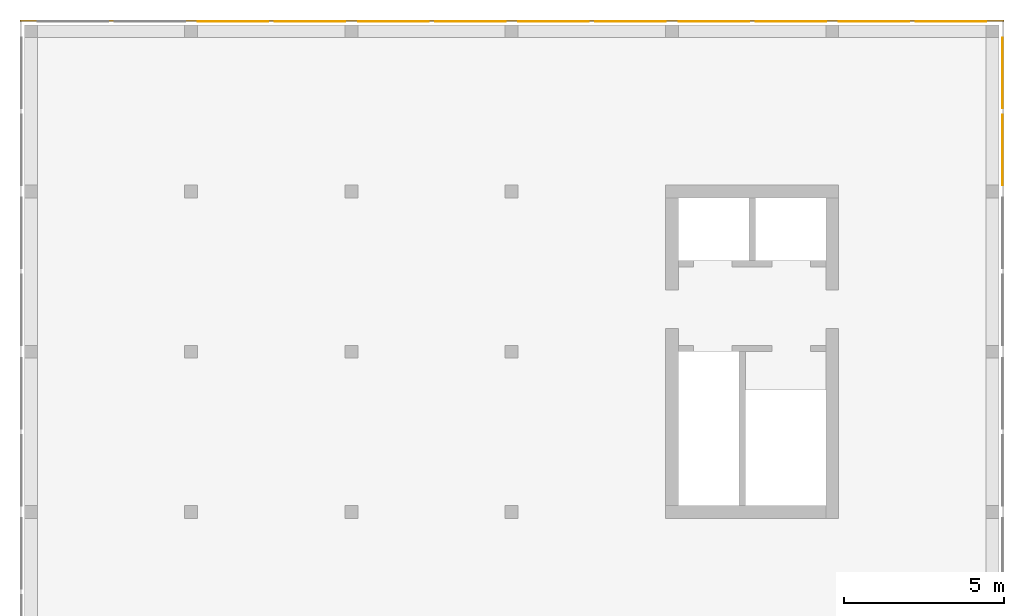
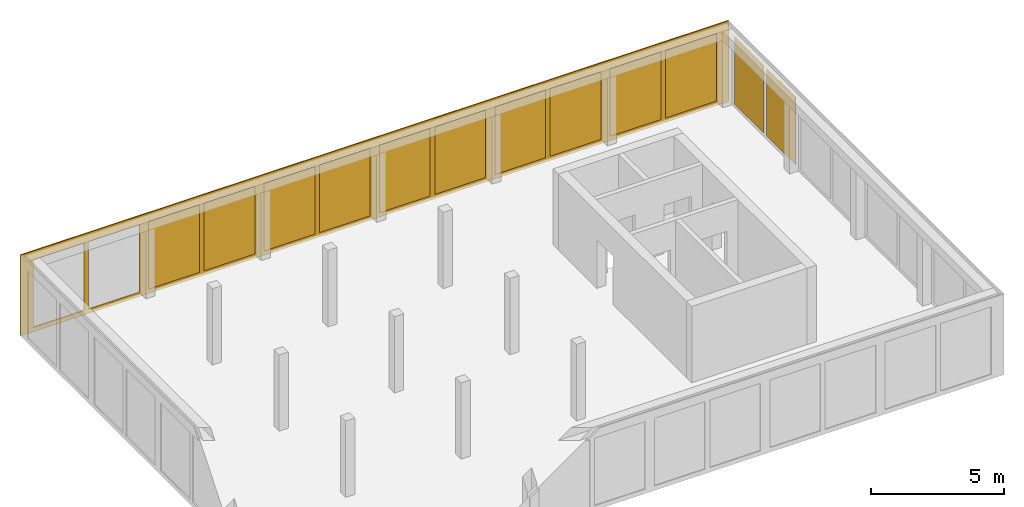
# One storey, part 3 of 3: 13 curtain walls.
"""IFC2X3 building model written with IfcOpenShell, lengths in metres."""

from ifc_helpers import new_model, entity, si_unit, converted_unit, frame, origin, place, context, subcontext, project, spatial, faceted_brep, material, element, save


model = new_model("IFC2X3")

# Units and contexts
model_context = context("Model", 3, precision=1e-05, world=origin())
body_context = subcontext(model_context, "Body", "Model", "MODEL_VIEW")
ifc_project = project(units=[si_unit("LENGTHUNIT", "METRE"), si_unit("AREAUNIT", "SQUARE_METRE"), si_unit("VOLUMEUNIT", "CUBIC_METRE"), si_unit("MASSUNIT", "GRAM", prefix="KILO"), converted_unit("PLANEANGLEUNIT", "DEGREE", entity("IfcPlaneAngleMeasure", 0.0174532925199433), si_unit("PLANEANGLEUNIT", "RADIAN"), dimensions=[0, 0, 0, 0, 0, 0, 0])], contexts=[model_context])

# Site, building, storey
site_placement = place(None, origin())
site = spatial("IfcSite", under=ifc_project, at=site_placement, CompositionType="ELEMENT")
building_placement = place(site_placement, origin())
building = spatial("IfcBuilding", under=site, at=building_placement, CompositionType="ELEMENT")
storey_placement = place(building_placement, frame((0.0, 0.0, 16.0)))
storey = spatial("IfcBuildingStorey", under=building, at=storey_placement, Name="4. Obergeschoss", CompositionType="ELEMENT", Elevation=16.0)

# Curtain walls
ifc_material_1 = material(Name="ALU")
curtain_wall_1_placement = place(storey_placement, frame((-0.139330706017223, 20.5, -0.2)))
element("IfcCurtainWall", 1, at=curtain_wall_1_placement, inside=storey, material=ifc_material_1, Name="Profil SN standard", context=body_context, shape_type="Brep", body=[
    faceted_brep([(0.0, 0.05, 3.7), (30.7, 0.05, 3.7), (30.7, 0.0, 3.7), (0.0, 0.0, 3.7), (30.7, 0.05, 0.0), (0.0, 0.05, 0.0), (0.0, 0.0, 0.0), (30.7, 0.0, 0.0), (27.95, 0.0, 0.2), (27.95, 0.0, 3.3), (27.95, 0.05, 3.3), (27.95, 0.05, 0.2), (27.75, 0.05, 0.2), (27.75, 0.05, 3.3), (27.75, 0.0, 3.3), (27.75, 0.0, 0.2), (22.95, 0.0, 0.2), (22.95, 0.0, 3.3), (22.95, 0.05, 3.3), (22.95, 0.05, 0.2), (22.75, 0.05, 0.2), (22.75, 0.05, 3.3), (22.75, 0.0, 3.3), (22.75, 0.0, 0.2), (17.75, 0.05, 0.2), (17.75, 0.05, 3.3), (17.75, 0.0, 3.3), (17.75, 0.0, 0.2), (17.95, 0.0, 0.2), (17.95, 0.0, 3.3), (17.95, 0.05, 3.3), (17.95, 0.05, 0.2), (25.15, 0.0, 0.2), (25.15, 0.05, 0.2), (25.15, 0.05, 3.3), (25.15, 0.0, 3.3), (25.55, 0.05, 0.2), (25.55, 0.0, 0.2), (25.55, 0.0, 3.3), (25.55, 0.05, 3.3), (20.15, 0.0, 0.2), (20.15, 0.05, 0.2), (20.15, 0.05, 3.3), (20.15, 0.0, 3.3), (20.55, 0.05, 0.2), (20.55, 0.0, 0.2), (20.55, 0.0, 3.3), (20.55, 0.05, 3.3), (30.15, 0.0, 0.2), (30.15, 0.05, 0.2), (30.15, 0.05, 3.3), (30.15, 0.0, 3.3), (2.75, 0.05, 0.2), (2.75, 0.05, 3.3), (2.75, 0.0, 3.3), (2.75, 0.0, 0.2), (2.95, 0.0, 0.2), (2.95, 0.0, 3.3), (2.95, 0.05, 3.3), (2.95, 0.05, 0.2), (12.75, 0.05, 0.2), (12.75, 0.05, 3.3), (12.75, 0.0, 3.3), (12.75, 0.0, 0.2), (12.95, 0.0, 0.2), (12.95, 0.0, 3.3), (12.95, 0.05, 3.3), (12.95, 0.05, 0.2), (7.75, 0.05, 0.2), (7.75, 0.05, 3.3), (7.75, 0.0, 3.3), (7.75, 0.0, 0.2), (7.95, 0.0, 0.2), (7.95, 0.0, 3.3), (7.95, 0.05, 3.3), (7.95, 0.05, 0.2), (15.55, 0.0, 0.2), (15.55, 0.05, 0.2), (15.55, 0.0, 3.3), (15.55, 0.05, 3.3), (10.55, 0.05, 3.3), (10.55, 0.0, 3.3), (15.15, 0.0, 3.3), (15.15, 0.05, 3.3), (15.15, 0.0, 0.2), (15.15, 0.05, 0.2), (10.55, 0.0, 0.2), (10.55, 0.05, 0.2), (0.550000000000002, 0.05, 3.3), (0.550000000000002, 0.0, 3.3), (5.15, 0.0, 3.3), (5.15, 0.05, 3.3), (5.15, 0.0, 0.2), (5.15, 0.05, 0.2), (0.550000000000002, 0.0, 0.2), (0.550000000000002, 0.05, 0.2), (5.55, 0.05, 0.2), (5.55, 0.0, 0.2), (5.55, 0.0, 3.3), (5.55, 0.05, 3.3), (10.15, 0.0, 3.3), (10.15, 0.05, 3.3), (10.15, 0.0, 0.2), (10.15, 0.05, 0.2)], [[[0, 1, 2, 3]], [[4, 5, 6, 7]], [[7, 2, 1, 4]], [[5, 0, 3, 6]], [[8, 9, 10, 11]], [[12, 13, 14, 15]], [[16, 17, 18, 19]], [[20, 21, 22, 23]], [[24, 25, 26, 27]], [[28, 29, 30, 31]], [[32, 33, 34, 35]], [[36, 37, 38, 39]], [[40, 41, 42, 43]], [[44, 45, 46, 47]], [[48, 49, 50, 51]], [[52, 53, 54, 55]], [[56, 57, 58, 59]], [[60, 61, 62, 63]], [[64, 65, 66, 67]], [[68, 69, 70, 71]], [[72, 73, 74, 75]], [[31, 41, 40, 28]], [[27, 76, 77, 24]], [[77, 76, 78, 79]], [[25, 79, 78, 26]], [[29, 43, 42, 30]], [[61, 80, 81, 62]], [[65, 82, 83, 66]], [[84, 85, 83, 82]], [[67, 85, 84, 64]], [[63, 86, 87, 60]], [[87, 86, 81, 80]], [[53, 88, 89, 54]], [[57, 90, 91, 58]], [[92, 93, 91, 90]], [[59, 93, 92, 56]], [[55, 94, 95, 52]], [[95, 94, 89, 88]], [[96, 97, 98, 99]], [[69, 99, 98, 70]], [[73, 100, 101, 74]], [[102, 103, 101, 100]], [[75, 103, 102, 72]], [[71, 97, 96, 68]], [[19, 33, 32, 16]], [[23, 45, 44, 20]], [[21, 47, 46, 22]], [[17, 35, 34, 18]], [[11, 49, 48, 8]], [[15, 37, 36, 12]], [[13, 39, 38, 14]], [[9, 51, 50, 10]], [[2, 7, 6, 3], [102, 100, 73, 72], [92, 90, 57, 56], [84, 82, 65, 64], [70, 98, 97, 71], [62, 81, 86, 63], [29, 28, 40, 43], [54, 89, 94, 55], [26, 78, 76, 27], [16, 32, 35, 17], [46, 45, 23, 22], [8, 48, 51, 9], [38, 37, 15, 14]], [[0, 5, 4, 1], [95, 88, 53, 52], [96, 99, 69, 68], [87, 80, 61, 60], [74, 101, 103, 75], [66, 83, 85, 67], [58, 91, 93, 59], [77, 79, 25, 24], [30, 42, 41, 31], [20, 44, 47, 21], [34, 33, 19, 18], [12, 36, 39, 13], [50, 49, 11, 10]]], orient=[[False], [False], [False], [False], [False], [False], [False], [False], [False], [False], [False], [False], [False], [False], [False], [False], [False], [False], [False], [False], [False], [False], [False], [False], [False], [False], [False], [False], [False], [False], [False], [False], [False], [False], [False], [False], [False], [False], [False], [False], [False], [False], [False], [False], [False], [False], [False], [False], [False], [False], [False], [False], [False, False, False, False, False, False, False, False, False, False, False, False, False], [False, False, False, False, False, False, False, False, False, False, False, False, False]]),
])
ifc_material_2 = material(Name="VSG")
curtain_wall_2_placement = place(storey_placement, frame((5.41066929398277, 20.5, 0.0)))
element("IfcCurtainWall", 2, at=curtain_wall_2_placement, inside=storey, material=ifc_material_2, Name="standard", context=body_context, shape_type="Brep", body=[
    faceted_brep([(2.2, 0.0, 0.0), (2.2, 0.0, 3.1), (2.2, 0.005, 3.1), (2.2, 0.005, 0.0), (0.0, 0.005, 3.1), (0.0, 0.005, 0.0), (0.0, 0.0, 3.1), (0.0, 0.0, 0.0)], [[[0, 1, 2, 3]], [[3, 2, 4, 5]], [[5, 4, 6, 7]], [[7, 6, 1, 0]], [[6, 4, 2, 1]], [[0, 3, 5, 7]]], orient=[[False], [False], [False], [False], [False], [False]]),
])
ifc_material_3 = material(Name="VSG")
curtain_wall_3_placement = place(storey_placement, frame((7.81066929398278, 20.5, 0.0)))
element("IfcCurtainWall", 3, at=curtain_wall_3_placement, inside=storey, material=ifc_material_3, Name="standard", context=body_context, shape_type="Brep", body=[
    faceted_brep([(2.2, 0.0, 0.0), (2.2, 0.0, 3.1), (2.2, 0.005, 3.1), (2.2, 0.005, 0.0), (0.0, 0.005, 3.1), (0.0, 0.005, 0.0), (0.0, 0.0, 3.1), (0.0, 0.0, 0.0)], [[[0, 1, 2, 3]], [[3, 2, 4, 5]], [[5, 4, 6, 7]], [[7, 6, 1, 0]], [[6, 4, 2, 1]], [[0, 3, 5, 7]]], orient=[[False], [False], [False], [False], [False], [False]]),
])
ifc_material_4 = material(Name="VSG")
curtain_wall_4_placement = place(storey_placement, frame((10.4106692939828, 20.5, 0.0)))
element("IfcCurtainWall", 4, at=curtain_wall_4_placement, inside=storey, material=ifc_material_4, Name="standard", context=body_context, shape_type="Brep", body=[
    faceted_brep([(2.2, 0.0, 0.0), (2.2, 0.0, 3.1), (2.2, 0.005, 3.1), (2.2, 0.005, 0.0), (0.0, 0.005, 3.1), (0.0, 0.005, 0.0), (0.0, 0.0, 3.1), (0.0, 0.0, 0.0)], [[[0, 1, 2, 3]], [[3, 2, 4, 5]], [[5, 4, 6, 7]], [[7, 6, 1, 0]], [[6, 4, 2, 1]], [[0, 3, 5, 7]]], orient=[[False], [False], [False], [False], [False], [False]]),
])
ifc_material_5 = material(Name="VSG")
curtain_wall_5_placement = place(storey_placement, frame((12.8106692939828, 20.5, 0.0)))
element("IfcCurtainWall", 5, at=curtain_wall_5_placement, inside=storey, material=ifc_material_5, Name="standard", context=body_context, shape_type="Brep", body=[
    faceted_brep([(2.2, 0.0, 0.0), (2.2, 0.0, 3.1), (2.2, 0.005, 3.1), (2.2, 0.005, 0.0), (0.0, 0.005, 3.1), (0.0, 0.005, 0.0), (0.0, 0.0, 3.1), (0.0, 0.0, 0.0)], [[[0, 1, 2, 3]], [[3, 2, 4, 5]], [[5, 4, 6, 7]], [[7, 6, 1, 0]], [[6, 4, 2, 1]], [[0, 3, 5, 7]]], orient=[[False], [False], [False], [False], [False], [False]]),
])
ifc_material_6 = material(Name="VSG")
curtain_wall_6_placement = place(storey_placement, frame((15.4106692939828, 20.5, 0.0)))
element("IfcCurtainWall", 6, at=curtain_wall_6_placement, inside=storey, material=ifc_material_6, Name="standard", context=body_context, shape_type="Brep", body=[
    faceted_brep([(2.20000000000001, 0.0, 0.0), (2.20000000000001, 0.0, 3.1), (2.20000000000001, 0.005, 3.1), (2.20000000000001, 0.005, 0.0), (1.81898940354586e-15, 0.005, 3.1), (1.81898940354586e-15, 0.005, 0.0), (1.81898940354586e-15, 0.0, 3.1), (1.81898940354586e-15, 0.0, 0.0)], [[[0, 1, 2, 3]], [[3, 2, 4, 5]], [[5, 4, 6, 7]], [[7, 6, 1, 0]], [[6, 4, 2, 1]], [[0, 3, 5, 7]]], orient=[[False], [False], [False], [False], [False], [False]]),
])
ifc_material_7 = material(Name="VSG")
curtain_wall_7_placement = place(storey_placement, frame((17.8106692939828, 20.5, 0.0)))
element("IfcCurtainWall", 7, at=curtain_wall_7_placement, inside=storey, material=ifc_material_7, Name="standard", context=body_context, shape_type="Brep", body=[
    faceted_brep([(2.2, 0.0, 0.0), (2.2, 0.0, 3.1), (2.2, 0.005, 3.1), (2.2, 0.005, 0.0), (0.0, 0.005, 3.1), (0.0, 0.005, 0.0), (0.0, 0.0, 3.1), (0.0, 0.0, 0.0)], [[[0, 1, 2, 3]], [[3, 2, 4, 5]], [[5, 4, 6, 7]], [[7, 6, 1, 0]], [[6, 4, 2, 1]], [[0, 3, 5, 7]]], orient=[[False], [False], [False], [False], [False], [False]]),
])
ifc_material_8 = material(Name="VSG")
curtain_wall_8_placement = place(storey_placement, frame((20.4106692939828, 20.5, 0.0)))
element("IfcCurtainWall", 8, at=curtain_wall_8_placement, inside=storey, material=ifc_material_8, Name="standard", context=body_context, shape_type="Brep", body=[
    faceted_brep([(2.2, 0.0, 0.0), (2.2, 0.0, 3.1), (2.2, 0.005, 3.1), (2.2, 0.005, 0.0), (0.0, 0.005, 3.1), (0.0, 0.005, 0.0), (0.0, 0.0, 3.1), (0.0, 0.0, 0.0)], [[[0, 1, 2, 3]], [[3, 2, 4, 5]], [[5, 4, 6, 7]], [[7, 6, 1, 0]], [[6, 4, 2, 1]], [[0, 3, 5, 7]]], orient=[[False], [False], [False], [False], [False], [False]]),
])
ifc_material_9 = material(Name="VSG")
curtain_wall_9_placement = place(storey_placement, frame((22.8106692939828, 20.5, 0.0)))
element("IfcCurtainWall", 9, at=curtain_wall_9_placement, inside=storey, material=ifc_material_9, Name="standard", context=body_context, shape_type="Brep", body=[
    faceted_brep([(2.2, 0.0, 0.0), (2.2, 0.0, 3.1), (2.2, 0.005, 3.1), (2.2, 0.005, 0.0), (0.0, 0.005, 3.1), (0.0, 0.005, 0.0), (0.0, 0.0, 3.1), (0.0, 0.0, 0.0)], [[[0, 1, 2, 3]], [[3, 2, 4, 5]], [[5, 4, 6, 7]], [[7, 6, 1, 0]], [[6, 4, 2, 1]], [[0, 3, 5, 7]]], orient=[[False], [False], [False], [False], [False], [False]]),
])
ifc_material_10 = material(Name="VSG")
curtain_wall_10_placement = place(storey_placement, frame((25.4106692939828, 20.5, 0.0)))
element("IfcCurtainWall", 10, at=curtain_wall_10_placement, inside=storey, material=ifc_material_10, Name="standard", context=body_context, shape_type="Brep", body=[
    faceted_brep([(2.2, 0.0, 0.0), (2.2, 0.0, 3.1), (2.2, 0.005, 3.1), (2.2, 0.005, 0.0), (0.0, 0.005, 3.1), (0.0, 0.005, 0.0), (0.0, 0.0, 3.1), (0.0, 0.0, 0.0)], [[[0, 1, 2, 3]], [[3, 2, 4, 5]], [[5, 4, 6, 7]], [[7, 6, 1, 0]], [[6, 4, 2, 1]], [[0, 3, 5, 7]]], orient=[[False], [False], [False], [False], [False], [False]]),
])
ifc_material_11 = material(Name="VSG")
curtain_wall_11_placement = place(storey_placement, frame((27.8106692939828, 20.5, 0.0)))
element("IfcCurtainWall", 11, at=curtain_wall_11_placement, inside=storey, material=ifc_material_11, Name="standard", context=body_context, shape_type="Brep", body=[
    faceted_brep([(2.2, 0.0, 0.0), (2.2, 0.0, 3.1), (2.2, 0.005, 3.1), (2.2, 0.005, 0.0), (0.0, 0.005, 3.1), (0.0, 0.005, 0.0), (0.0, 0.0, 3.1), (0.0, 0.0, 0.0)], [[[0, 1, 2, 3]], [[3, 2, 4, 5]], [[5, 4, 6, 7]], [[7, 6, 1, 0]], [[6, 4, 2, 1]], [[0, 3, 5, 7]]], orient=[[False], [False], [False], [False], [False], [False]]),
])
ifc_material_12 = material(Name="VSG")
curtain_wall_12_placement = place(storey_placement, frame((30.5106692939828, 17.8, 0.0)))
element("IfcCurtainWall", 12, at=curtain_wall_12_placement, inside=storey, material=ifc_material_12, Name="standard", context=body_context, shape_type="Brep", body=[
    faceted_brep([(0.0, -3.63797880709171e-15, 0.0), (0.0, -3.63797880709171e-15, 3.1), (0.005, -3.63797880709171e-15, 3.1), (0.005, -3.63797880709171e-15, 0.0), (0.005, 2.2, 3.1), (0.005, 2.2, 0.0), (0.0, 2.2, 3.1), (0.0, 2.2, 0.0)], [[[0, 1, 2, 3]], [[3, 2, 4, 5]], [[5, 4, 6, 7]], [[7, 6, 1, 0]], [[6, 4, 2, 1]], [[0, 3, 5, 7]]], orient=[[False], [False], [False], [False], [False], [False]]),
])
ifc_material_13 = material(Name="VSG")
curtain_wall_13_placement = place(storey_placement, frame((30.5106692939828, 15.4, 0.0)))
element("IfcCurtainWall", 13, at=curtain_wall_13_placement, inside=storey, material=ifc_material_13, Name="standard", context=body_context, shape_type="Brep", body=[
    faceted_brep([(0.0, -1.81898940354586e-15, 0.0), (0.0, -1.81898940354586e-15, 3.1), (0.005, -1.81898940354586e-15, 3.1), (0.005, -1.81898940354586e-15, 0.0), (0.005, 2.2, 3.1), (0.005, 2.2, 0.0), (0.0, 2.2, 3.1), (0.0, 2.2, 0.0)], [[[0, 1, 2, 3]], [[3, 2, 4, 5]], [[5, 4, 6, 7]], [[7, 6, 1, 0]], [[6, 4, 2, 1]], [[0, 3, 5, 7]]], orient=[[False], [False], [False], [False], [False], [False]]),
])

save(model, "model.ifc")
